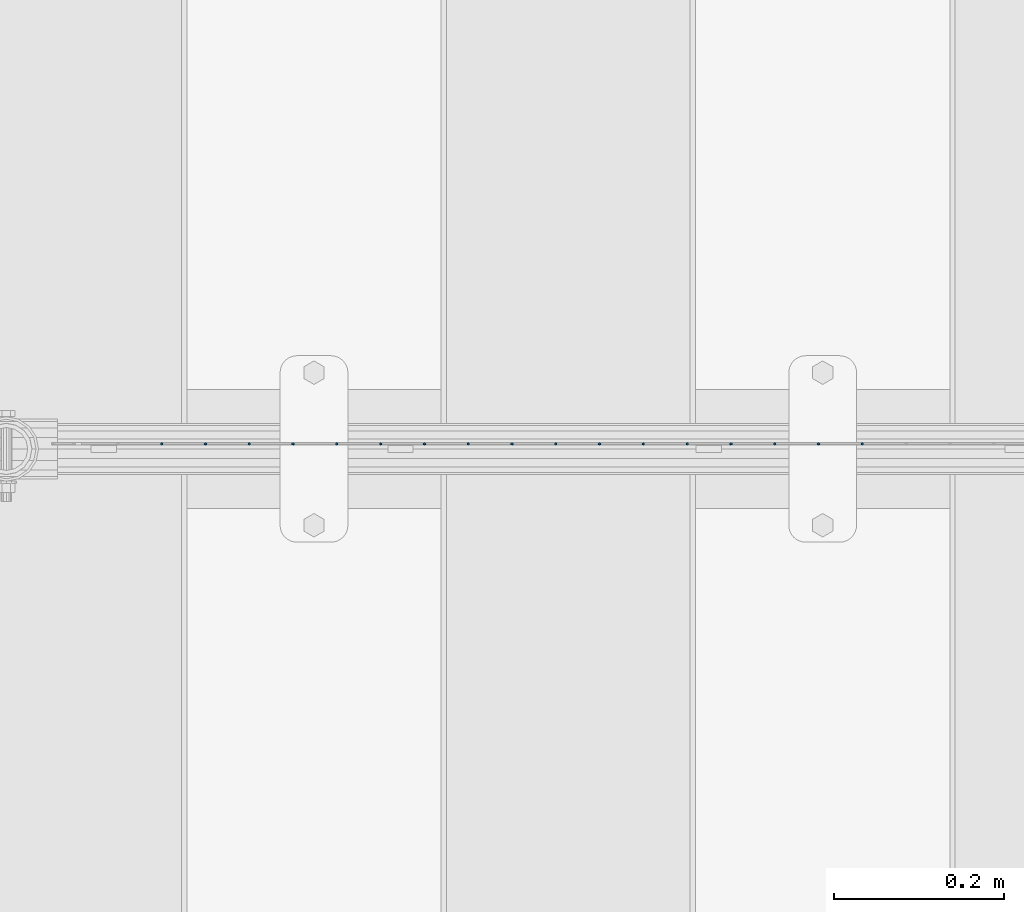
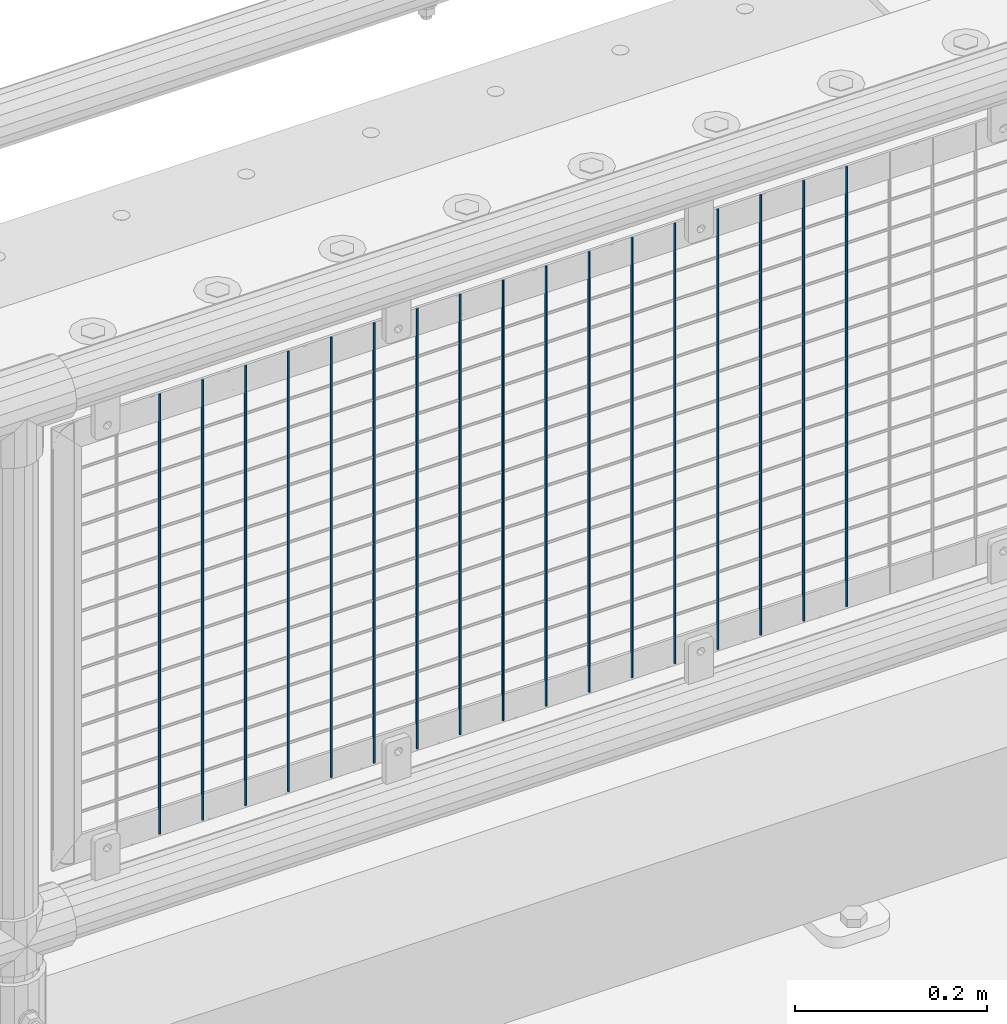
# One storey, part 61 of 193: 17 columns.
"""IFC2X3 building model written with IfcOpenShell, lengths in millimetres."""

from ifc_helpers import new_model, si_unit, frame, origin_with_axes, place, context, subcontext, project, spatial, faceted_brep, material, type_object, element, save


model = new_model("IFC2X3")

# Units and contexts
model_context = context("Model", 3, precision=1e-05, world=origin_with_axes())
body_context = subcontext(model_context, "Body", "Model", "MODEL_VIEW")
ifc_project = project(units=[si_unit("LENGTHUNIT", "METRE", prefix="MILLI"), si_unit("AREAUNIT", "SQUARE_METRE"), si_unit("VOLUMEUNIT", "CUBIC_METRE"), si_unit("MASSUNIT", "GRAM", prefix="KILO"), si_unit("TIMEUNIT", "SECOND"), si_unit("PLANEANGLEUNIT", "RADIAN"), si_unit("SOLIDANGLEUNIT", "STERADIAN"), si_unit("THERMODYNAMICTEMPERATUREUNIT", "DEGREE_CELSIUS"), si_unit("LUMINOUSINTENSITYUNIT", "LUMEN")], contexts=[model_context])

# Site, building, storey
site_placement = place(None, origin_with_axes())
site = spatial("IfcSite", under=ifc_project, at=site_placement, CompositionType="ELEMENT")
building_placement = place(site_placement, origin_with_axes())
building = spatial("IfcBuilding", under=site, at=building_placement, Name="Standard", CompositionType="ELEMENT")
storey_placement = place(building_placement, origin_with_axes())
storey = spatial("IfcBuildingStorey", under=building, at=storey_placement, Name="Undefined", CompositionType="ELEMENT", Elevation=0.0)

# Columns
ifc_material = material(Name="Misc_Undefined")
column_type = type_object("IfcColumnType", Name="D3", PredefinedType="NOTDEFINED")
for number, where, z_axis, x_axis in (
    (1, (-37503.21, 28670.5, 353.02), (-1.0, 0.0, 0.0), (0.0, 0.0, 1.0)),
    (2, (-37554.865, 28670.5, 353.02), (-1.0, 0.0, 0.0), (0.0, 0.0, 1.0)),
    (3, (-37606.52, 28670.5, 353.02), (-1.0, 0.0, 0.0), (0.0, 0.0, 1.0)),
    (4, (-37658.175, 28670.5, 353.02), (-1.0, 0.0, 0.0), (0.0, 0.0, 1.0)),
    (5, (-37709.83, 28670.5, 353.02), (-1.0, 0.0, 0.0), (0.0, 0.0, 1.0)),
    (6, (-37761.485, 28670.5, 353.02), (-1.0, 0.0, 0.0), (0.0, 0.0, 1.0)),
    (7, (-37813.14, 28670.5, 353.02), (-1.0, 0.0, 0.0), (0.0, 0.0, 1.0)),
    (8, (-37864.795, 28670.5, 353.02), (-1.0, 0.0, 0.0), (0.0, 0.0, 1.0)),
    (9, (-37916.45, 28670.5, 353.02), (-1.0, 0.0, 0.0), (0.0, 0.0, 1.0)),
    (10, (-37968.105, 28670.5, 353.02), (-1.0, 0.0, 0.0), (0.0, 0.0, 1.0)),
    (11, (-38019.76, 28670.5, 353.02), (-1.0, 0.0, 0.0), (0.0, 0.0, 1.0)),
    (12, (-38071.415, 28670.5, 353.02), (-1.0, 0.0, 0.0), (0.0, 0.0, 1.0)),
    (13, (-38123.07, 28670.5, 353.02), (-1.0, 0.0, 0.0), (0.0, 0.0, 1.0)),
    (14, (-38174.725, 28670.5, 353.02), (-1.0, 0.0, 0.0), (0.0, 0.0, 1.0)),
    (15, (-38226.38, 28670.5, 353.02), (-1.0, 0.0, 0.0), (0.0, 0.0, 1.0)),
    (16, (-38278.035, 28670.5, 353.02), (-1.0, 0.0, 0.0), (0.0, 0.0, 1.0)),
    (17, (-38329.69, 28670.5, 353.02), (-1.0, 0.0, 0.0), (0.0, 0.0, 1.0)),
):
    element("IfcColumn", number, at=place(storey_placement, frame(where, z_axis=z_axis, x_axis=x_axis)), inside=storey, type_object=column_type, material=ifc_material, ObjectType="D3", context=body_context, shape_type="Brep", body=[
        faceted_brep([(0.0, -1.49999999999636, 3.63797880709171e-12), (0.0, -0.75, -1.29903810567669), (560.0, -0.75, -1.29903810567703), (560.0, -1.5, 0.0), (0.0, 0.75, -1.29903810567669), (560.0, 0.75, -1.29903810567703), (0.0, 1.50000000000364, 7.27595761418343e-12), (560.0, 1.5, 0.0), (0.0, 0.75, 1.29903810567669), (560.0, 0.75, 1.29903810567703), (0.0, -0.75, 1.29903810567669), (560.0, -0.75, 1.29903810567703)], [[[0, 1, 2, 3]], [[1, 4, 5, 2]], [[4, 6, 7, 5]], [[6, 8, 9, 7]], [[8, 10, 11, 9]], [[10, 0, 3, 11]], [[5, 7, 9, 11, 3, 2]], [[10, 8, 6, 4, 1, 0]]]),
    ])

save(model, "model.ifc")
